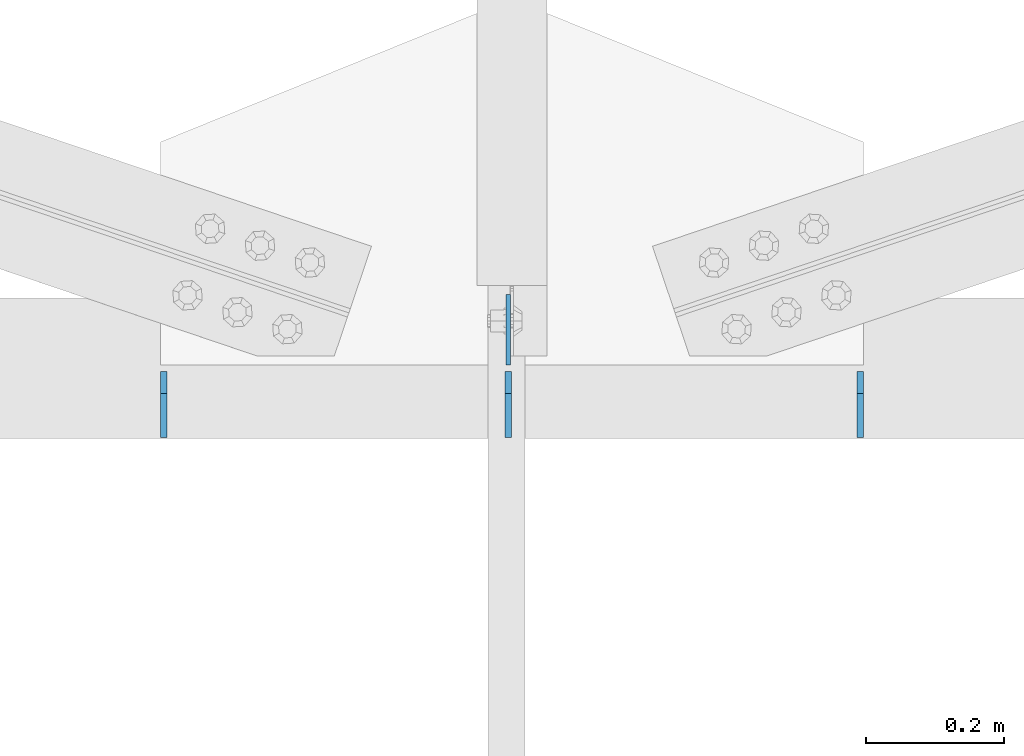
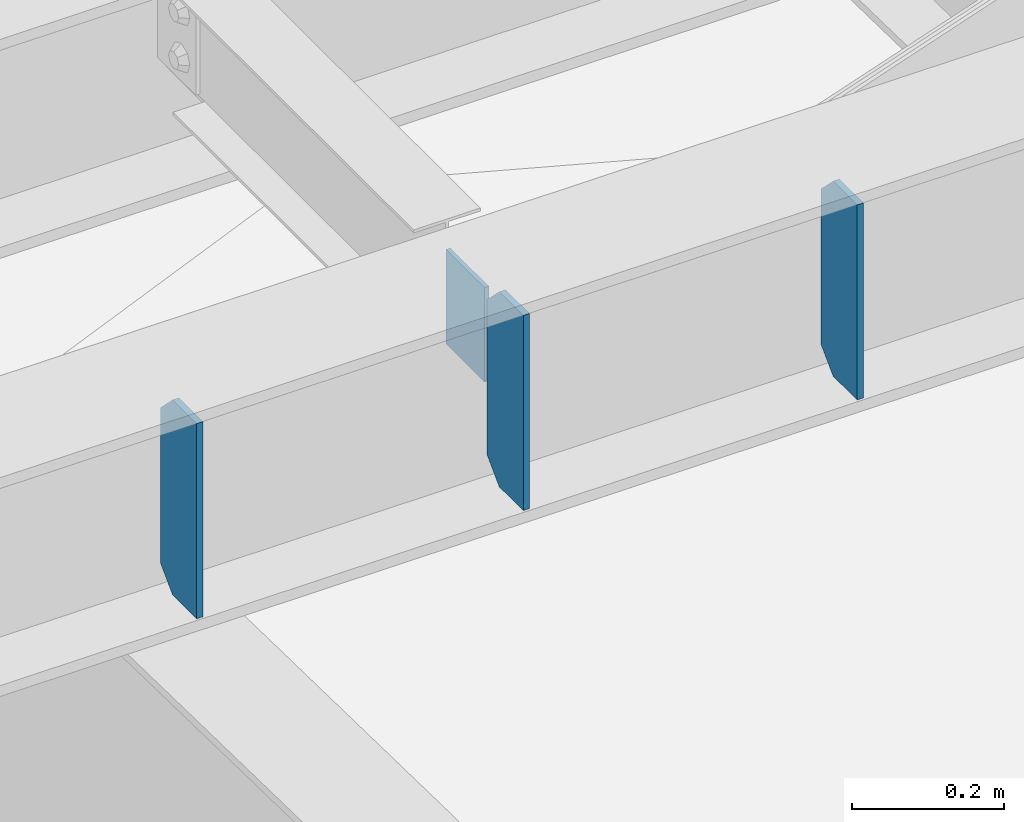
# One storey, part 1459 of 1763: 4 plates, 1 element without a shape of its own.
"""IFC2X3 building model written with IfcOpenShell, lengths in millimetres."""

from ifc_helpers import new_model, si_unit, frame, origin_with_axes, place, context, subcontext, project, spatial, faceted_brep, material, type_object, element, aggregate, save


model = new_model("IFC2X3")

# Units and contexts
model_context = context("Model", 3, precision=1e-05, world=origin_with_axes())
body_context = subcontext(model_context, "Body", "Model", "MODEL_VIEW")
ifc_project = project(units=[si_unit("LENGTHUNIT", "METRE", prefix="MILLI"), si_unit("AREAUNIT", "SQUARE_METRE"), si_unit("VOLUMEUNIT", "CUBIC_METRE"), si_unit("MASSUNIT", "GRAM", prefix="KILO"), si_unit("TIMEUNIT", "SECOND"), si_unit("PLANEANGLEUNIT", "RADIAN"), si_unit("SOLIDANGLEUNIT", "STERADIAN"), si_unit("THERMODYNAMICTEMPERATUREUNIT", "DEGREE_CELSIUS"), si_unit("LUMINOUSINTENSITYUNIT", "LUMEN")], contexts=[model_context])

# Site, building, storey
site_placement = place(None, origin_with_axes())
site = spatial("IfcSite", under=ifc_project, at=site_placement, CompositionType="ELEMENT")
building_placement = place(site_placement, origin_with_axes())
building = spatial("IfcBuilding", under=site, at=building_placement, Name="Undefined", CompositionType="ELEMENT")
storey_placement = place(building_placement, origin_with_axes())
storey = spatial("IfcBuildingStorey", under=building, at=storey_placement, Name="Undefined", CompositionType="ELEMENT", Elevation=0.0)

# Assembly, plates
assembly_placement = place(storey_placement, origin_with_axes())
assembly = element("IfcElementAssembly", 1, at=assembly_placement, inside=storey, Name="BEAM", AssemblyPlace="NOTDEFINED", PredefinedType="RIGID_FRAME")
ifc_material = material(Name="STEEL/A36")
plate_type_1 = type_object("IfcPlateType", PredefinedType="NOTDEFINED")
plate_1_placement = place(assembly_placement, frame((-55478.5837019159, -15447.9647626132, 18783.3), z_axis=(0.0, 1.0, 0.0), x_axis=(0.0, 0.0, -1.0)))
plate_1 = element("IfcPlate", 2, at=plate_1_placement, type_object=plate_type_1, material=ifc_material, Name="PLATE", context=body_context, shape_type="Brep", body=[
    faceted_brep([(1.81898940354586e-12, -3.17500000000291, 0.0), (0.0, -3.17499999999927, 101.599998474121), (0.0, 3.17499999999927, 101.599998474121), (-1.81898940354586e-12, 3.17499999997381, 0.0), (152.399993896484, -3.17499999999927, 101.599998474121), (152.399993896484, 3.17499999999927, 101.599998474121), (152.399993896484, -3.17500000000291, 0.0), (152.399993896484, 3.17500000000291, 0.0)], [[[0, 1, 2, 3]], [[1, 4, 5, 2]], [[4, 6, 7, 5]], [[6, 0, 3, 7]], [[5, 7, 3, 2]], [[6, 4, 1, 0]]]),
])
plate_type_2 = type_object("IfcPlateType", PredefinedType="NOTDEFINED")
plate_2_placement = place(assembly_placement, frame((-55976.2649571967, -15552.7397593523, 18488.025), z_axis=(0.0, 0.0, 1.0), x_axis=(0.0, 1.0, 0.0)))
plate_2 = element("IfcPlate", 3, at=plate_2_placement, type_object=plate_type_2, material=ifc_material, Name="PLATE", context=body_context, shape_type="Brep", body=[
    faceted_brep([(0.0, -4.76249999999982, 0.0), (-7.27595761418343e-12, -4.76250000000073, 314.325000762939), (7.27595761418343e-12, 4.76250000000437, 314.325000762939), (0.0, 4.76249999999982, 0.0), (63.4999999999964, -4.76250000017171, 314.325012207031), (63.5000000000036, 4.76249999982974, 314.325012207031), (95.2499999999964, -4.76250000025902, 282.575012207031), (95.2500000000036, 4.76249999974243, 282.575012207031), (95.2499999999964, -4.76250000025902, 31.75), (95.2500000000036, 4.76249999974243, 31.75), (63.4999999999964, -4.76250000017171, 0.0), (63.5000000000036, 4.76249999982974, 0.0)], [[[0, 1, 2, 3]], [[1, 4, 5, 2]], [[4, 6, 7, 5]], [[6, 8, 9, 7]], [[8, 10, 11, 9]], [[10, 0, 3, 11]], [[5, 7, 9, 11, 3, 2]], [[10, 8, 6, 4, 1, 0]]]),
])
plate_3_placement = place(assembly_placement, frame((-55478.583702545, -15552.7397623384, 18488.025), z_axis=(0.0, 0.0, 1.0), x_axis=(0.0, 1.0, 0.0)))
plate_3 = element("IfcPlate", 4, at=plate_3_placement, type_object=plate_type_2, material=ifc_material, Name="PLATE", context=body_context, shape_type="Brep", body=[
    faceted_brep([(0.0, -4.76249999999982, 0.0), (-7.27595761418343e-12, -4.76250000000073, 314.325000762939), (7.27595761418343e-12, 4.76250000000437, 314.325000762939), (0.0, 4.76249999999982, 0.0), (63.4999999999964, -4.76250000017171, 314.325012207031), (63.5000000000036, 4.76249999982974, 314.325012207031), (95.2499999999964, -4.76250000025902, 282.575012207031), (95.2500000000036, 4.76249999974243, 282.575012207031), (95.2499999999964, -4.76250000025902, 31.75), (95.2500000000036, 4.76249999974243, 31.75), (63.4999999999964, -4.76250000017171, 0.0), (63.5000000000036, 4.76249999982974, 0.0)], [[[0, 1, 2, 3]], [[1, 4, 5, 2]], [[4, 6, 7, 5]], [[6, 8, 9, 7]], [[8, 10, 11, 9]], [[10, 0, 3, 11]], [[5, 7, 9, 11, 3, 2]], [[10, 8, 6, 4, 1, 0]]]),
])
plate_4_placement = place(assembly_placement, frame((-54969.7899571969, -15552.7397653911, 18488.025), z_axis=(0.0, 0.0, 1.0), x_axis=(0.0, 1.0, 0.0)))
plate_4 = element("IfcPlate", 5, at=plate_4_placement, type_object=plate_type_2, material=ifc_material, Name="PLATE", context=body_context, shape_type="Brep", body=[
    faceted_brep([(0.0, -4.76249999999982, 0.0), (-7.27595761418343e-12, -4.76250000000073, 314.325000762939), (7.27595761418343e-12, 4.76250000000437, 314.325000762939), (0.0, 4.76249999999982, 0.0), (63.4999999999964, -4.76250000017171, 314.325012207031), (63.5000000000036, 4.76249999982974, 314.325012207031), (95.2499999999964, -4.76250000025902, 282.575012207031), (95.2500000000036, 4.76249999974243, 282.575012207031), (95.2499999999964, -4.76250000025902, 31.75), (95.2500000000036, 4.76249999974243, 31.75), (63.4999999999964, -4.76250000017171, 0.0), (63.5000000000036, 4.76249999982974, 0.0)], [[[0, 1, 2, 3]], [[1, 4, 5, 2]], [[4, 6, 7, 5]], [[6, 8, 9, 7]], [[8, 10, 11, 9]], [[10, 0, 3, 11]], [[5, 7, 9, 11, 3, 2]], [[10, 8, 6, 4, 1, 0]]]),
])
aggregate(assembly, [plate_2, plate_3, plate_4, plate_1])

save(model, "model.ifc")
